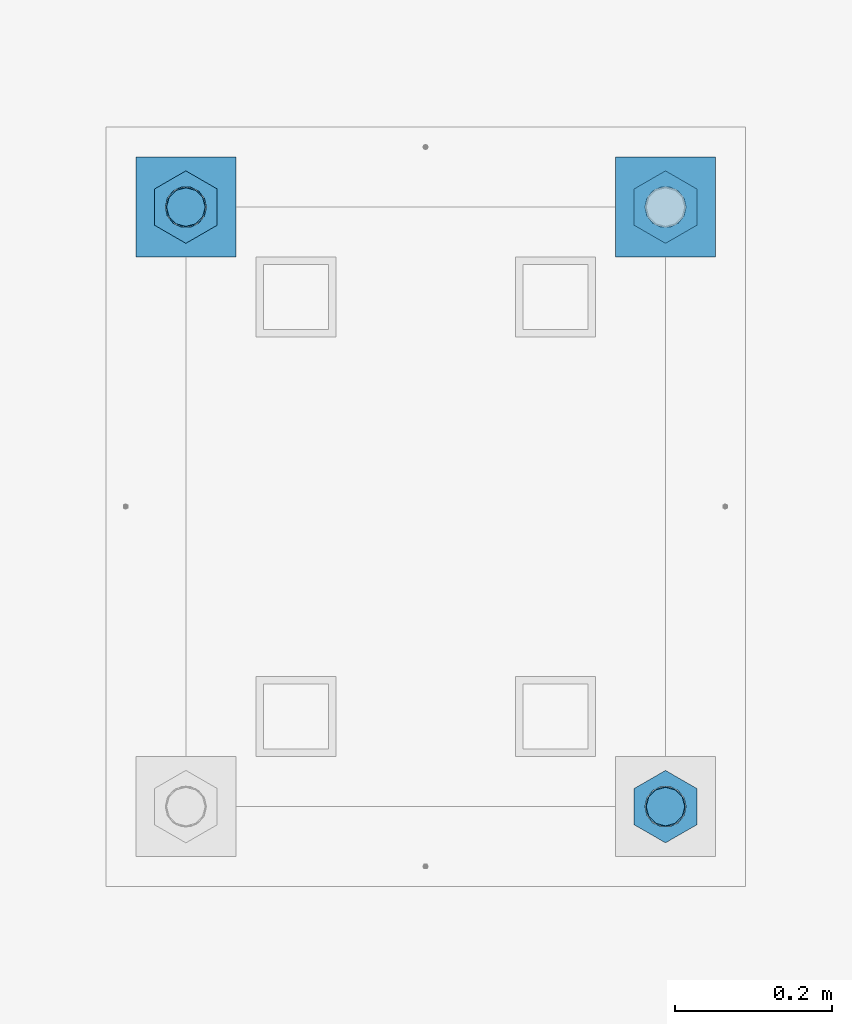
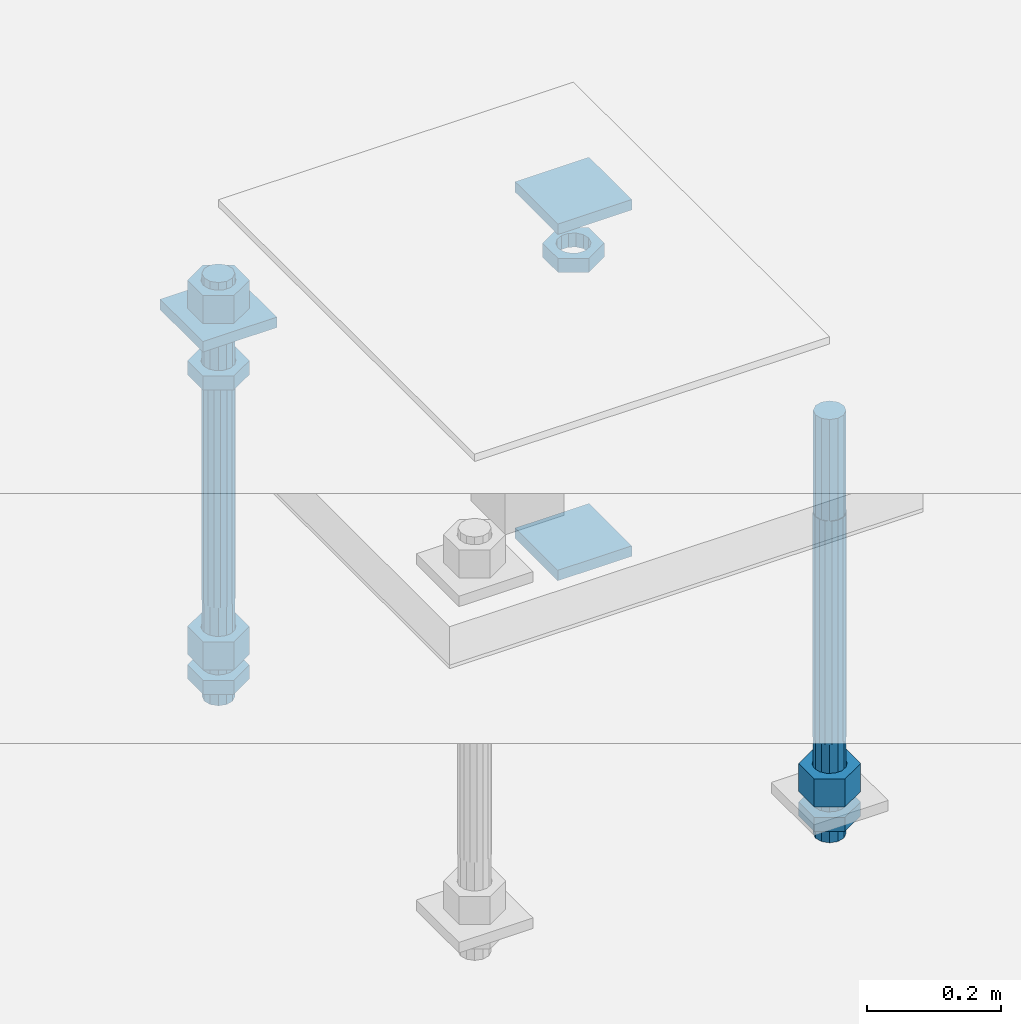
# One storey, part 2623 of 3843: 12 beams, 1 element without a shape of its own.
"""IFC2X3 building model written with IfcOpenShell, lengths in millimetres."""

from ifc_helpers import new_model, si_unit, frame, origin_with_axes, place, context, subcontext, project, spatial, faceted_brep, material, type_object, element, aggregate, save


model = new_model("IFC2X3")

# Units and contexts
model_context = context("Model", 3, precision=1e-05, world=origin_with_axes())
body_context = subcontext(model_context, "Body", "Model", "MODEL_VIEW")
ifc_project = project(units=[si_unit("LENGTHUNIT", "METRE", prefix="MILLI"), si_unit("AREAUNIT", "SQUARE_METRE"), si_unit("VOLUMEUNIT", "CUBIC_METRE"), si_unit("MASSUNIT", "GRAM", prefix="KILO"), si_unit("TIMEUNIT", "SECOND"), si_unit("PLANEANGLEUNIT", "RADIAN"), si_unit("SOLIDANGLEUNIT", "STERADIAN"), si_unit("THERMODYNAMICTEMPERATUREUNIT", "DEGREE_CELSIUS"), si_unit("LUMINOUSINTENSITYUNIT", "LUMEN")], contexts=[model_context])

# Site, building, storey
site_placement = place(None, origin_with_axes())
site = spatial("IfcSite", under=ifc_project, at=site_placement, CompositionType="ELEMENT")
building_placement = place(site_placement, origin_with_axes())
building = spatial("IfcBuilding", under=site, at=building_placement, Name="Undefined", CompositionType="ELEMENT")
storey_placement = place(building_placement, origin_with_axes())
storey = spatial("IfcBuildingStorey", under=building, at=storey_placement, Name="Undefined", CompositionType="ELEMENT", Elevation=0.0)

# Assembly, beams
assembly_placement = place(storey_placement, origin_with_axes())
assembly = element("IfcElementAssembly", 1, at=assembly_placement, inside=storey, Name="TEMPLATE", AssemblyPlace="NOTDEFINED", PredefinedType="RIGID_FRAME")
ifc_material_1 = material(Name="STEEL/A36")
beam_type_1 = type_object("IfcBeamType", PredefinedType="NOTDEFINED")
beam_1_placement = place(assembly_placement, frame((116471.7, 2032.0, 29873.575), z_axis=(0.0, 1.0, 0.0), x_axis=(-1.0, 0.0, 0.0)))
beam_1 = element("IfcBeam", 2, at=beam_1_placement, type_object=beam_type_1, material=ifc_material_1, Name="WASHER_PLATE", context=body_context, shape_type="Brep", body=[
    faceted_brep([(0.0, 9.52500000000146, -63.5), (0.0, 9.52500000000146, 63.5), (127.0, 9.52500000000146, 63.5), (127.0, 9.52500000000146, -63.5), (0.0, -9.52500000000146, 63.5), (127.0, -9.52500000000146, 63.5), (0.0, -9.52500000000146, -63.5), (127.0, -9.52500000000146, -63.5)], [[[0, 1, 2, 3]], [[1, 4, 5, 2]], [[4, 6, 7, 5]], [[6, 0, 3, 7]], [[5, 7, 3, 2]], [[6, 4, 1, 0]]]),
])
beam_2_placement = place(assembly_placement, frame((115862.099998474, 2032.0, 29873.575), z_axis=(0.0, 1.0, 0.0), x_axis=(-1.0, 0.0, 0.0)))
beam_2 = element("IfcBeam", 3, at=beam_2_placement, type_object=beam_type_1, material=ifc_material_1, Name="WASHER_PLATE", context=body_context, shape_type="Brep", body=[
    faceted_brep([(0.0, 9.52500000000146, -63.5), (0.0, 9.52500000000146, 63.5), (127.0, 9.52500000000146, 63.5), (127.0, 9.52500000000146, -63.5), (0.0, -9.52500000000146, 63.5), (127.0, -9.52500000000146, 63.5), (0.0, -9.52500000000146, -63.5), (127.0, -9.52500000000146, -63.5)], [[[0, 1, 2, 3]], [[1, 4, 5, 2]], [[4, 6, 7, 5]], [[6, 0, 3, 7]], [[5, 7, 3, 2]], [[6, 4, 1, 0]]]),
])
beam_3_placement = place(assembly_placement, frame((116471.7, 2032.00000000001, 29244.925), z_axis=(0.0, 1.0, 0.0), x_axis=(-1.0, 0.0, 0.0)))
beam_3 = element("IfcBeam", 4, at=beam_3_placement, type_object=beam_type_1, material=ifc_material_1, Name="WASHER_PLATE", context=body_context, shape_type="Brep", body=[
    faceted_brep([(0.0, 9.52500000000146, -63.5), (0.0, 9.52500000000146, 63.5), (127.0, 9.52500000000146, 63.5), (127.0, 9.52500000000146, -63.5), (0.0, -9.52500000000146, 63.5), (127.0, -9.52500000000146, 63.5), (0.0, -9.52500000000146, -63.5), (127.0, -9.52500000000146, -63.5)], [[[0, 1, 2, 3]], [[1, 4, 5, 2]], [[4, 6, 7, 5]], [[6, 0, 3, 7]], [[5, 7, 3, 2]], [[6, 4, 1, 0]]]),
])
beam_type_2 = type_object("IfcBeamType", Name="2_HALF_NUT", PredefinedType="NOTDEFINED")
beam_4_placement = place(assembly_placement, frame((115798.599998474, 2032.00000000001, 29787.85), z_axis=(-1.0, 0.0, 0.0), x_axis=(0.0, 0.0, -1.0)))
beam_4 = element("IfcBeam", 5, at=beam_4_placement, type_object=beam_type_2, material=ifc_material_1, Name="NUT", ObjectType="2_HALF_NUT", context=body_context, shape_type="Brep", body=[
    faceted_brep([(0.0, -46.0369987487793, 0.0), (0.0, -23.0184993743896, -39.869213104248), (25.4000000000015, -23.0184993743896, -39.869213104248), (25.4000000000015, -46.0369987487793, 0.0), (0.0, 23.0184993743896, -39.869213104248), (25.4000000000015, 23.0184993743896, -39.869213104248), (0.0, 46.0369987487793, 0.0), (25.4000000000015, 46.0369987487793, 0.0), (0.0, 23.0184993743896, 39.869213104248), (25.4000000000015, 23.0184993743896, 39.869213104248), (0.0, -23.0184993743896, 39.869213104248), (25.4000000000015, -23.0184993743896, 39.869213104248), (0.0, 0.0, 26.1940002441406), (0.0, 11.3650617044477, 23.5999013092805), (25.4000000000015, 11.3650617044477, 23.5999013092805), (25.4000000000015, 0.0, 26.1940002441406), (0.0, 20.4791109456419, 16.3316083006721), (25.4000000000015, 20.4791109456419, 16.3316083006721), (0.0, 25.5370200498292, 5.82867859874386), (25.4000000000015, 25.5370200498292, 5.82867859874386), (0.0, 25.5370200498292, -5.82867859874386), (25.4000000000015, 25.5370200498292, -5.82867859874386), (0.0, 20.4791109456419, -16.3316083006721), (25.4000000000015, 20.4791109456419, -16.3316083006721), (0.0, 11.3650617044477, -23.5999013092805), (25.4000000000015, 11.3650617044477, -23.5999013092805), (0.0, 0.0, -26.1940002441406), (25.4000000000015, 0.0, -26.1940002441406), (0.0, -11.3650617044477, -23.5999013092805), (25.4000000000015, -11.3650617044477, -23.5999013092805), (0.0, -20.4791109456419, -16.3316083006721), (25.4000000000015, -20.4791109456419, -16.3316083006721), (0.0, -25.5370200498292, -5.82867859874386), (25.4000000000015, -25.5370200498292, -5.82867859874386), (0.0, -25.5370200498292, 5.82867859874386), (25.4000000000015, -25.5370200498292, 5.82867859874386), (0.0, -20.4791109456419, 16.3316083006721), (25.4000000000015, -20.4791109456419, 16.3316083006721), (0.0, -11.3650617044477, 23.5999013092805), (25.4000000000015, -11.3650617044477, 23.5999013092805)], [[[0, 1, 2, 3]], [[1, 4, 5, 2]], [[4, 6, 7, 5]], [[6, 8, 9, 7]], [[8, 10, 11, 9]], [[10, 0, 3, 11]], [[12, 13, 14, 15]], [[13, 16, 17, 14]], [[16, 18, 19, 17]], [[18, 20, 21, 19]], [[20, 22, 23, 21]], [[22, 24, 25, 23]], [[24, 26, 27, 25]], [[26, 28, 29, 27]], [[28, 30, 31, 29]], [[30, 32, 33, 31]], [[32, 34, 35, 33]], [[34, 36, 37, 35]], [[36, 38, 39, 37]], [[38, 12, 15, 39]], [[5, 7, 9, 11, 3, 2], [17, 19, 21, 23, 25, 27, 29, 31, 33, 35, 37, 39, 15, 14]], [[10, 8, 6, 4, 1, 0], [38, 36, 34, 32, 30, 28, 26, 24, 22, 20, 18, 16, 13, 12]]]),
])
beam_5_placement = place(assembly_placement, frame((115798.599998474, 2032.0, 29235.4), z_axis=(-1.0, 0.0, 0.0), x_axis=(0.0, 0.0, -1.0)))
beam_5 = element("IfcBeam", 6, at=beam_5_placement, type_object=beam_type_2, material=ifc_material_1, Name="NUT", ObjectType="2_HALF_NUT", context=body_context, shape_type="Brep", body=[
    faceted_brep([(0.0, -46.0369987487793, 0.0), (0.0, -23.0184993743896, -39.869213104248), (25.4000000000015, -23.0184993743896, -39.869213104248), (25.4000000000015, -46.0369987487793, 0.0), (0.0, 23.0184993743896, -39.869213104248), (25.4000000000015, 23.0184993743896, -39.869213104248), (0.0, 46.0369987487793, 0.0), (25.4000000000015, 46.0369987487793, 0.0), (0.0, 23.0184993743896, 39.869213104248), (25.4000000000015, 23.0184993743896, 39.869213104248), (0.0, -23.0184993743896, 39.869213104248), (25.4000000000015, -23.0184993743896, 39.869213104248), (0.0, 0.0, 26.1940002441406), (0.0, 11.3650617044477, 23.5999013092805), (25.4000000000015, 11.3650617044477, 23.5999013092805), (25.4000000000015, 0.0, 26.1940002441406), (0.0, 20.4791109456419, 16.3316083006721), (25.4000000000015, 20.4791109456419, 16.3316083006721), (0.0, 25.5370200498292, 5.82867859874386), (25.4000000000015, 25.5370200498292, 5.82867859874386), (0.0, 25.5370200498292, -5.82867859874386), (25.4000000000015, 25.5370200498292, -5.82867859874386), (0.0, 20.4791109456419, -16.3316083006721), (25.4000000000015, 20.4791109456419, -16.3316083006721), (0.0, 11.3650617044477, -23.5999013092805), (25.4000000000015, 11.3650617044477, -23.5999013092805), (0.0, 0.0, -26.1940002441406), (25.4000000000015, 0.0, -26.1940002441406), (0.0, -11.3650617044477, -23.5999013092805), (25.4000000000015, -11.3650617044477, -23.5999013092805), (0.0, -20.4791109456419, -16.3316083006721), (25.4000000000015, -20.4791109456419, -16.3316083006721), (0.0, -25.5370200498292, -5.82867859874386), (25.4000000000015, -25.5370200498292, -5.82867859874386), (0.0, -25.5370200498292, 5.82867859874386), (25.4000000000015, -25.5370200498292, 5.82867859874386), (0.0, -20.4791109456419, 16.3316083006721), (25.4000000000015, -20.4791109456419, 16.3316083006721), (0.0, -11.3650617044477, 23.5999013092805), (25.4000000000015, -11.3650617044477, 23.5999013092805)], [[[0, 1, 2, 3]], [[1, 4, 5, 2]], [[4, 6, 7, 5]], [[6, 8, 9, 7]], [[8, 10, 11, 9]], [[10, 0, 3, 11]], [[12, 13, 14, 15]], [[13, 16, 17, 14]], [[16, 18, 19, 17]], [[18, 20, 21, 19]], [[20, 22, 23, 21]], [[22, 24, 25, 23]], [[24, 26, 27, 25]], [[26, 28, 29, 27]], [[28, 30, 31, 29]], [[30, 32, 33, 31]], [[32, 34, 35, 33]], [[34, 36, 37, 35]], [[36, 38, 39, 37]], [[38, 12, 15, 39]], [[5, 7, 9, 11, 3, 2], [17, 19, 21, 23, 25, 27, 29, 31, 33, 35, 37, 39, 15, 14]], [[10, 8, 6, 4, 1, 0], [38, 36, 34, 32, 30, 28, 26, 24, 22, 20, 18, 16, 13, 12]]]),
])
beam_6_placement = place(assembly_placement, frame((116408.2, 1270.0, 29235.4), z_axis=(-1.0, 0.0, 0.0), x_axis=(0.0, 0.0, -1.0)))
beam_6 = element("IfcBeam", 7, at=beam_6_placement, type_object=beam_type_2, material=ifc_material_1, Name="NUT", ObjectType="2_HALF_NUT", context=body_context, shape_type="Brep", body=[
    faceted_brep([(0.0, -46.0369987487793, 0.0), (0.0, -23.0184993743896, -39.869213104248), (25.4000000000015, -23.0184993743896, -39.869213104248), (25.4000000000015, -46.0369987487793, 0.0), (0.0, 23.0184993743896, -39.869213104248), (25.4000000000015, 23.0184993743896, -39.869213104248), (0.0, 46.0369987487793, 0.0), (25.4000000000015, 46.0369987487793, 0.0), (0.0, 23.0184993743896, 39.869213104248), (25.4000000000015, 23.0184993743896, 39.869213104248), (0.0, -23.0184993743896, 39.869213104248), (25.4000000000015, -23.0184993743896, 39.869213104248), (0.0, 0.0, 26.1940002441406), (0.0, 11.3650617044477, 23.5999013092805), (25.4000000000015, 11.3650617044477, 23.5999013092805), (25.4000000000015, 0.0, 26.1940002441406), (0.0, 20.4791109456419, 16.3316083006721), (25.4000000000015, 20.4791109456419, 16.3316083006721), (0.0, 25.5370200498292, 5.82867859874386), (25.4000000000015, 25.5370200498292, 5.82867859874386), (0.0, 25.5370200498292, -5.82867859874386), (25.4000000000015, 25.5370200498292, -5.82867859874386), (0.0, 20.4791109456419, -16.3316083006721), (25.4000000000015, 20.4791109456419, -16.3316083006721), (0.0, 11.3650617044477, -23.5999013092805), (25.4000000000015, 11.3650617044477, -23.5999013092805), (0.0, 0.0, -26.1940002441406), (25.4000000000015, 0.0, -26.1940002441406), (0.0, -11.3650617044477, -23.5999013092805), (25.4000000000015, -11.3650617044477, -23.5999013092805), (0.0, -20.4791109456419, -16.3316083006721), (25.4000000000015, -20.4791109456419, -16.3316083006721), (0.0, -25.5370200498292, -5.82867859874386), (25.4000000000015, -25.5370200498292, -5.82867859874386), (0.0, -25.5370200498292, 5.82867859874386), (25.4000000000015, -25.5370200498292, 5.82867859874386), (0.0, -20.4791109456419, 16.3316083006721), (25.4000000000015, -20.4791109456419, 16.3316083006721), (0.0, -11.3650617044477, 23.5999013092805), (25.4000000000015, -11.3650617044477, 23.5999013092805)], [[[0, 1, 2, 3]], [[1, 4, 5, 2]], [[4, 6, 7, 5]], [[6, 8, 9, 7]], [[8, 10, 11, 9]], [[10, 0, 3, 11]], [[12, 13, 14, 15]], [[13, 16, 17, 14]], [[16, 18, 19, 17]], [[18, 20, 21, 19]], [[20, 22, 23, 21]], [[22, 24, 25, 23]], [[24, 26, 27, 25]], [[26, 28, 29, 27]], [[28, 30, 31, 29]], [[30, 32, 33, 31]], [[32, 34, 35, 33]], [[34, 36, 37, 35]], [[36, 38, 39, 37]], [[38, 12, 15, 39]], [[5, 7, 9, 11, 3, 2], [17, 19, 21, 23, 25, 27, 29, 31, 33, 35, 37, 39, 15, 14]], [[10, 8, 6, 4, 1, 0], [38, 36, 34, 32, 30, 28, 26, 24, 22, 20, 18, 16, 13, 12]]]),
])
beam_7_placement = place(assembly_placement, frame((116408.2, 2032.00000000001, 29787.85), z_axis=(-1.0, 0.0, 0.0), x_axis=(0.0, 0.0, -1.0)))
beam_7 = element("IfcBeam", 8, at=beam_7_placement, type_object=beam_type_2, material=ifc_material_1, Name="NUT", ObjectType="2_HALF_NUT", context=body_context, shape_type="Brep", body=[
    faceted_brep([(0.0, -46.0369987487793, 0.0), (0.0, -23.0184993743896, -39.869213104248), (25.4000000000015, -23.0184993743896, -39.869213104248), (25.4000000000015, -46.0369987487793, 0.0), (0.0, 23.0184993743896, -39.869213104248), (25.4000000000015, 23.0184993743896, -39.869213104248), (0.0, 46.0369987487793, 0.0), (25.4000000000015, 46.0369987487793, 0.0), (0.0, 23.0184993743896, 39.869213104248), (25.4000000000015, 23.0184993743896, 39.869213104248), (0.0, -23.0184993743896, 39.869213104248), (25.4000000000015, -23.0184993743896, 39.869213104248), (0.0, 0.0, 26.1940002441406), (0.0, 11.3650617044477, 23.5999013092805), (25.4000000000015, 11.3650617044477, 23.5999013092805), (25.4000000000015, 0.0, 26.1940002441406), (0.0, 20.4791109456419, 16.3316083006721), (25.4000000000015, 20.4791109456419, 16.3316083006721), (0.0, 25.5370200498292, 5.82867859874386), (25.4000000000015, 25.5370200498292, 5.82867859874386), (0.0, 25.5370200498292, -5.82867859874386), (25.4000000000015, 25.5370200498292, -5.82867859874386), (0.0, 20.4791109456419, -16.3316083006721), (25.4000000000015, 20.4791109456419, -16.3316083006721), (0.0, 11.3650617044477, -23.5999013092805), (25.4000000000015, 11.3650617044477, -23.5999013092805), (0.0, 0.0, -26.1940002441406), (25.4000000000015, 0.0, -26.1940002441406), (0.0, -11.3650617044477, -23.5999013092805), (25.4000000000015, -11.3650617044477, -23.5999013092805), (0.0, -20.4791109456419, -16.3316083006721), (25.4000000000015, -20.4791109456419, -16.3316083006721), (0.0, -25.5370200498292, -5.82867859874386), (25.4000000000015, -25.5370200498292, -5.82867859874386), (0.0, -25.5370200498292, 5.82867859874386), (25.4000000000015, -25.5370200498292, 5.82867859874386), (0.0, -20.4791109456419, 16.3316083006721), (25.4000000000015, -20.4791109456419, 16.3316083006721), (0.0, -11.3650617044477, 23.5999013092805), (25.4000000000015, -11.3650617044477, 23.5999013092805)], [[[0, 1, 2, 3]], [[1, 4, 5, 2]], [[4, 6, 7, 5]], [[6, 8, 9, 7]], [[8, 10, 11, 9]], [[10, 0, 3, 11]], [[12, 13, 14, 15]], [[13, 16, 17, 14]], [[16, 18, 19, 17]], [[18, 20, 21, 19]], [[20, 22, 23, 21]], [[22, 24, 25, 23]], [[24, 26, 27, 25]], [[26, 28, 29, 27]], [[28, 30, 31, 29]], [[30, 32, 33, 31]], [[32, 34, 35, 33]], [[34, 36, 37, 35]], [[36, 38, 39, 37]], [[38, 12, 15, 39]], [[5, 7, 9, 11, 3, 2], [17, 19, 21, 23, 25, 27, 29, 31, 33, 35, 37, 39, 15, 14]], [[10, 8, 6, 4, 1, 0], [38, 36, 34, 32, 30, 28, 26, 24, 22, 20, 18, 16, 13, 12]]]),
])
beam_type_3 = type_object("IfcBeamType", Name="2_HEAVY_HEX_NUT", PredefinedType="NOTDEFINED")
beam_8_placement = place(assembly_placement, frame((115798.599998474, 2032.00000000001, 29933.9), z_axis=(-1.0, 0.0, 0.0), x_axis=(0.0, 0.0, -1.0)))
beam_8 = element("IfcBeam", 9, at=beam_8_placement, type_object=beam_type_3, material=ifc_material_1, Name="NUT", ObjectType="2_HEAVY_HEX_NUT", context=body_context, shape_type="Brep", body=[
    faceted_brep([(0.0, -46.0369987487793, 0.0), (0.0, -23.0184993743896, -39.869213104248), (50.7999999999993, -23.0184993743896, -39.869213104248), (50.7999999999993, -46.0369987487793, 0.0), (0.0, 23.0184993743896, -39.869213104248), (50.7999999999993, 23.0184993743896, -39.869213104248), (0.0, 46.0369987487793, 0.0), (50.7999999999993, 46.0369987487793, 0.0), (0.0, 23.0184993743896, 39.869213104248), (50.7999999999993, 23.0184993743896, 39.869213104248), (0.0, -23.0184993743896, 39.869213104248), (50.7999999999993, -23.0184993743896, 39.869213104248), (0.0, 0.0, 26.1940002441406), (0.0, 11.3650617044477, 23.5999013092805), (50.7999999999993, 11.3650617044477, 23.5999013092805), (50.7999999999993, 0.0, 26.1940002441406), (0.0, 20.4791109456419, 16.3316083006721), (50.7999999999993, 20.4791109456419, 16.3316083006721), (0.0, 25.5370200498292, 5.82867859874386), (50.7999999999993, 25.5370200498292, 5.82867859874386), (0.0, 25.5370200498292, -5.82867859874386), (50.7999999999993, 25.5370200498292, -5.82867859874386), (0.0, 20.4791109456419, -16.3316083006721), (50.7999999999993, 20.4791109456419, -16.3316083006721), (0.0, 11.3650617044477, -23.5999013092805), (50.7999999999993, 11.3650617044477, -23.5999013092805), (0.0, 0.0, -26.1940002441406), (50.7999999999993, 0.0, -26.1940002441406), (0.0, -11.3650617044477, -23.5999013092805), (50.7999999999993, -11.3650617044477, -23.5999013092805), (0.0, -20.4791109456419, -16.3316083006721), (50.7999999999993, -20.4791109456419, -16.3316083006721), (0.0, -25.5370200498292, -5.82867859874386), (50.7999999999993, -25.5370200498292, -5.82867859874386), (0.0, -25.5370200498292, 5.82867859874386), (50.7999999999993, -25.5370200498292, 5.82867859874386), (0.0, -20.4791109456419, 16.3316083006721), (50.7999999999993, -20.4791109456419, 16.3316083006721), (0.0, -11.3650617044477, 23.5999013092805), (50.7999999999993, -11.3650617044477, 23.5999013092805)], [[[0, 1, 2, 3]], [[1, 4, 5, 2]], [[4, 6, 7, 5]], [[6, 8, 9, 7]], [[8, 10, 11, 9]], [[10, 0, 3, 11]], [[12, 13, 14, 15]], [[13, 16, 17, 14]], [[16, 18, 19, 17]], [[18, 20, 21, 19]], [[20, 22, 23, 21]], [[22, 24, 25, 23]], [[24, 26, 27, 25]], [[26, 28, 29, 27]], [[28, 30, 31, 29]], [[30, 32, 33, 31]], [[32, 34, 35, 33]], [[34, 36, 37, 35]], [[36, 38, 39, 37]], [[38, 12, 15, 39]], [[5, 7, 9, 11, 3, 2], [17, 19, 21, 23, 25, 27, 29, 31, 33, 35, 37, 39, 15, 14]], [[10, 8, 6, 4, 1, 0], [38, 36, 34, 32, 30, 28, 26, 24, 22, 20, 18, 16, 13, 12]]]),
])
beam_9_placement = place(assembly_placement, frame((115798.599998474, 2032.00000000001, 29305.25), z_axis=(-1.0, 0.0, 0.0), x_axis=(0.0, 0.0, -1.0)))
beam_9 = element("IfcBeam", 10, at=beam_9_placement, type_object=beam_type_3, material=ifc_material_1, Name="NUT", ObjectType="2_HEAVY_HEX_NUT", context=body_context, shape_type="Brep", body=[
    faceted_brep([(0.0, -46.0369987487793, 0.0), (0.0, -23.0184993743896, -39.869213104248), (50.7999999999993, -23.0184993743896, -39.869213104248), (50.7999999999993, -46.0369987487793, 0.0), (0.0, 23.0184993743896, -39.869213104248), (50.7999999999993, 23.0184993743896, -39.869213104248), (0.0, 46.0369987487793, 0.0), (50.7999999999993, 46.0369987487793, 0.0), (0.0, 23.0184993743896, 39.869213104248), (50.7999999999993, 23.0184993743896, 39.869213104248), (0.0, -23.0184993743896, 39.869213104248), (50.7999999999993, -23.0184993743896, 39.869213104248), (0.0, 0.0, 26.1940002441406), (0.0, 11.3650617044477, 23.5999013092805), (50.7999999999993, 11.3650617044477, 23.5999013092805), (50.7999999999993, 0.0, 26.1940002441406), (0.0, 20.4791109456419, 16.3316083006721), (50.7999999999993, 20.4791109456419, 16.3316083006721), (0.0, 25.5370200498292, 5.82867859874386), (50.7999999999993, 25.5370200498292, 5.82867859874386), (0.0, 25.5370200498292, -5.82867859874386), (50.7999999999993, 25.5370200498292, -5.82867859874386), (0.0, 20.4791109456419, -16.3316083006721), (50.7999999999993, 20.4791109456419, -16.3316083006721), (0.0, 11.3650617044477, -23.5999013092805), (50.7999999999993, 11.3650617044477, -23.5999013092805), (0.0, 0.0, -26.1940002441406), (50.7999999999993, 0.0, -26.1940002441406), (0.0, -11.3650617044477, -23.5999013092805), (50.7999999999993, -11.3650617044477, -23.5999013092805), (0.0, -20.4791109456419, -16.3316083006721), (50.7999999999993, -20.4791109456419, -16.3316083006721), (0.0, -25.5370200498292, -5.82867859874386), (50.7999999999993, -25.5370200498292, -5.82867859874386), (0.0, -25.5370200498292, 5.82867859874386), (50.7999999999993, -25.5370200498292, 5.82867859874386), (0.0, -20.4791109456419, 16.3316083006721), (50.7999999999993, -20.4791109456419, 16.3316083006721), (0.0, -11.3650617044477, 23.5999013092805), (50.7999999999993, -11.3650617044477, 23.5999013092805)], [[[0, 1, 2, 3]], [[1, 4, 5, 2]], [[4, 6, 7, 5]], [[6, 8, 9, 7]], [[8, 10, 11, 9]], [[10, 0, 3, 11]], [[12, 13, 14, 15]], [[13, 16, 17, 14]], [[16, 18, 19, 17]], [[18, 20, 21, 19]], [[20, 22, 23, 21]], [[22, 24, 25, 23]], [[24, 26, 27, 25]], [[26, 28, 29, 27]], [[28, 30, 31, 29]], [[30, 32, 33, 31]], [[32, 34, 35, 33]], [[34, 36, 37, 35]], [[36, 38, 39, 37]], [[38, 12, 15, 39]], [[5, 7, 9, 11, 3, 2], [17, 19, 21, 23, 25, 27, 29, 31, 33, 35, 37, 39, 15, 14]], [[10, 8, 6, 4, 1, 0], [38, 36, 34, 32, 30, 28, 26, 24, 22, 20, 18, 16, 13, 12]]]),
])
beam_10_placement = place(assembly_placement, frame((116408.2, 1270.00000000001, 29305.25), z_axis=(-1.0, 0.0, 0.0), x_axis=(0.0, 0.0, -1.0)))
beam_10 = element("IfcBeam", 11, at=beam_10_placement, type_object=beam_type_3, material=ifc_material_1, Name="NUT", ObjectType="2_HEAVY_HEX_NUT", context=body_context, shape_type="Brep", body=[
    faceted_brep([(0.0, -46.0369987487793, 0.0), (0.0, -23.0184993743896, -39.869213104248), (50.7999999999993, -23.0184993743896, -39.869213104248), (50.7999999999993, -46.0369987487793, 0.0), (0.0, 23.0184993743896, -39.869213104248), (50.7999999999993, 23.0184993743896, -39.869213104248), (0.0, 46.0369987487793, 0.0), (50.7999999999993, 46.0369987487793, 0.0), (0.0, 23.0184993743896, 39.869213104248), (50.7999999999993, 23.0184993743896, 39.869213104248), (0.0, -23.0184993743896, 39.869213104248), (50.7999999999993, -23.0184993743896, 39.869213104248), (0.0, 0.0, 26.1940002441406), (0.0, 11.3650617044477, 23.5999013092805), (50.7999999999993, 11.3650617044477, 23.5999013092805), (50.7999999999993, 0.0, 26.1940002441406), (0.0, 20.4791109456419, 16.3316083006721), (50.7999999999993, 20.4791109456419, 16.3316083006721), (0.0, 25.5370200498292, 5.82867859874386), (50.7999999999993, 25.5370200498292, 5.82867859874386), (0.0, 25.5370200498292, -5.82867859874386), (50.7999999999993, 25.5370200498292, -5.82867859874386), (0.0, 20.4791109456419, -16.3316083006721), (50.7999999999993, 20.4791109456419, -16.3316083006721), (0.0, 11.3650617044477, -23.5999013092805), (50.7999999999993, 11.3650617044477, -23.5999013092805), (0.0, 0.0, -26.1940002441406), (50.7999999999993, 0.0, -26.1940002441406), (0.0, -11.3650617044477, -23.5999013092805), (50.7999999999993, -11.3650617044477, -23.5999013092805), (0.0, -20.4791109456419, -16.3316083006721), (50.7999999999993, -20.4791109456419, -16.3316083006721), (0.0, -25.5370200498292, -5.82867859874386), (50.7999999999993, -25.5370200498292, -5.82867859874386), (0.0, -25.5370200498292, 5.82867859874386), (50.7999999999993, -25.5370200498292, 5.82867859874386), (0.0, -20.4791109456419, 16.3316083006721), (50.7999999999993, -20.4791109456419, 16.3316083006721), (0.0, -11.3650617044477, 23.5999013092805), (50.7999999999993, -11.3650617044477, 23.5999013092805)], [[[0, 1, 2, 3]], [[1, 4, 5, 2]], [[4, 6, 7, 5]], [[6, 8, 9, 7]], [[8, 10, 11, 9]], [[10, 0, 3, 11]], [[12, 13, 14, 15]], [[13, 16, 17, 14]], [[16, 18, 19, 17]], [[18, 20, 21, 19]], [[20, 22, 23, 21]], [[22, 24, 25, 23]], [[24, 26, 27, 25]], [[26, 28, 29, 27]], [[28, 30, 31, 29]], [[30, 32, 33, 31]], [[32, 34, 35, 33]], [[34, 36, 37, 35]], [[36, 38, 39, 37]], [[38, 12, 15, 39]], [[5, 7, 9, 11, 3, 2], [17, 19, 21, 23, 25, 27, 29, 31, 33, 35, 37, 39, 15, 14]], [[10, 8, 6, 4, 1, 0], [38, 36, 34, 32, 30, 28, 26, 24, 22, 20, 18, 16, 13, 12]]]),
])
ifc_material_2 = material()
beam_type_4 = type_object("IfcBeamType", PredefinedType="NOTDEFINED")
beam_11_placement = place(assembly_placement, frame((115798.599998474, 2032.00000000001, 29762.45), z_axis=(-1.0, 0.0, 0.0), x_axis=(0.0, 0.0, -1.0)))
beam_11 = element("IfcBeam", 12, at=beam_11_placement, type_object=beam_type_4, material=ifc_material_2, Name="ANCHOR_ROD", context=body_context, shape_type="Brep", body=[
    faceted_brep([(-184.150000000001, -21.217622392709, 12.25), (-184.150000000001, -12.2499999999854, 21.2176223927163), (-184.150000000001, 1.45519152283669e-11, 24.5), (-184.150000000001, 12.2500000000146, 21.2176223927163), (-184.150000000001, 21.2176223927381, 12.25), (-184.150000000001, 24.5000000000146, 0.0), (-184.150000000001, 21.2176223927381, -12.25), (-184.150000000001, 12.2500000000146, -21.2176223927163), (-184.150000000001, 1.45519152283669e-11, -24.5), (-184.150000000001, -12.2499999999854, -21.2176223927163), (-184.150000000001, -21.217622392709, -12.25), (-184.150000000001, -24.4999999999854, 0.0), (0.0, 24.5000000000146, 0.0), (0.0, 21.2176223927381, -12.25), (0.0, 12.2500000000146, -21.2176223927163), (0.0, 1.45519152283669e-11, -24.5), (0.0, -12.2499999999854, -21.2176223927163), (0.0, -21.217622392709, -12.25), (0.0, -24.4999999999854, 0.0), (0.0, -21.217622392709, 12.25), (0.0, -12.2499999999854, 21.2176223927163), (0.0, 1.45519152283669e-11, 24.5), (0.0, 12.2500000000146, 21.2176223927163), (0.0, 21.2176223927381, 12.25), (0.0, -23.4665401257807, 9.72015918207035), (0.0, -17.9605122421344, 17.9605122421417), (0.0, -9.72015918207762, 23.466540125788), (0.0, 0.0, 25.4000000000015), (0.0, 9.72015918207762, 23.466540125788), (0.0, 17.9605122421344, 17.9605122421417), (0.0, 23.4665401257807, 9.72015918207035), (0.0, 25.3999996185303, 0.0), (0.0, 23.4665401257807, -9.72015918207035), (0.0, 17.9605122421344, -17.9605122421417), (0.0, 9.72015918207762, -23.466540125788), (0.0, 0.0, -25.4000000000015), (0.0, -9.72015918207762, -23.466540125788), (0.0, -17.9605122421344, -17.9605122421417), (0.0, -23.4665401257807, -9.72015918207035), (0.0, -25.3999996185303, 0.0), (406.399999999998, -25.3999999999942, 0.0), (406.399999999998, -23.4665401257807, 9.72015918207035), (406.399999999998, -17.9605122421344, 17.9605122421417), (406.399999999998, -9.72015918207762, 23.466540125788), (406.399999999998, 0.0, 25.4000000000015), (406.399999999998, 9.72015918207762, 23.466540125788), (406.399999999998, 17.9605122421344, 17.9605122421417), (406.399999999998, 23.4665401257807, 9.72015918207035), (406.399999999998, 25.3999999999942, 0.0), (406.399999999998, 23.4665401257807, -9.72015918207035), (406.399999999998, 17.9605122421344, -17.9605122421417), (406.399999999998, 9.72015918207762, -23.466540125788), (406.399999999998, 0.0, -25.4000000000015), (406.399999999998, -9.72015918207762, -23.466540125788), (406.399999999998, -17.9605122421344, -17.9605122421417), (406.399999999998, -23.4665401257807, -9.72015918207035), (406.399999999998, -12.2499999999854, 21.2176223927163), (406.399999999998, 1.45519152283669e-11, 24.5), (406.399999999998, 12.2500000000146, 21.2176223927163), (406.399999999998, 21.2176223927381, 12.25), (406.399999999998, 24.5000000000146, 0.0), (406.399999999998, 21.2176223927381, -12.25), (406.399999999998, 12.2500000000146, -21.2176223927163), (406.399999999998, 1.45519152283669e-11, -24.5), (406.399999999998, -12.2499999999854, -21.2176223927163), (406.399999999998, -21.217622392709, -12.25), (406.399999999998, -24.4999999999854, 0.0), (406.399999999998, -21.217622392709, 12.25), (584.200000000001, -12.2499999999854, -21.2176223927163), (584.200000000001, 1.45519152283669e-11, -24.5), (584.200000000001, 12.2500000000146, -21.2176223927163), (584.200000000001, 21.2176223927381, -12.25), (584.200000000001, 24.5000000000146, 0.0), (584.200000000001, 21.2176223927381, 12.25), (584.200000000001, 12.2500000000146, 21.2176223927163), (584.200000000001, 1.45519152283669e-11, 24.5), (584.200000000001, -12.2499999999854, 21.2176223927163), (584.200000000001, -21.217622392709, 12.25), (584.200000000001, -24.4999999999854, 0.0), (584.200000000001, -21.217622392709, -12.25)], [[[0, 1, 2, 3, 4, 5, 6, 7, 8, 9, 10, 11]], [[6, 5, 12, 13]], [[7, 6, 13, 14]], [[8, 7, 14, 15]], [[9, 8, 15, 16]], [[10, 9, 16, 17]], [[11, 10, 17, 18]], [[0, 11, 18, 19]], [[1, 0, 19, 20]], [[2, 1, 20, 21]], [[3, 2, 21, 22]], [[4, 3, 22, 23]], [[5, 4, 23, 12]], [[24, 25, 26, 27, 28, 29, 30, 31, 32, 33, 34, 35, 36, 37, 38, 39], [22, 21, 20, 19, 18, 17, 16, 15, 14, 13, 12, 23]], [[24, 39, 40, 41]], [[25, 24, 41, 42]], [[26, 25, 42, 43]], [[27, 26, 43, 44]], [[28, 27, 44, 45]], [[29, 28, 45, 46]], [[30, 29, 46, 47]], [[31, 30, 47, 48]], [[32, 31, 48, 49]], [[33, 32, 49, 50]], [[34, 33, 50, 51]], [[35, 34, 51, 52]], [[36, 35, 52, 53]], [[37, 36, 53, 54]], [[38, 37, 54, 55]], [[39, 38, 55, 40]], [[54, 53, 52, 51, 50, 49, 48, 47, 46, 45, 44, 43, 42, 41, 40, 55], [56, 57, 58, 59, 60, 61, 62, 63, 64, 65, 66, 67]], [[68, 69, 70, 71, 72, 73, 74, 75, 76, 77, 78, 79]], [[76, 75, 57, 56]], [[77, 76, 56, 67]], [[78, 77, 67, 66]], [[79, 78, 66, 65]], [[68, 79, 65, 64]], [[69, 68, 64, 63]], [[70, 69, 63, 62]], [[71, 70, 62, 61]], [[72, 71, 61, 60]], [[73, 72, 60, 59]], [[74, 73, 59, 58]], [[75, 74, 58, 57]]]),
])
beam_12_placement = place(assembly_placement, frame((116408.2, 1270.00000000001, 29762.45), z_axis=(-1.0, 0.0, 0.0), x_axis=(0.0, 0.0, -1.0)))
beam_12 = element("IfcBeam", 13, at=beam_12_placement, type_object=beam_type_4, material=ifc_material_2, Name="ANCHOR_ROD", context=body_context, shape_type="Brep", body=[
    faceted_brep([(-184.150000000001, -21.217622392709, 12.25), (-184.150000000001, -12.2499999999854, 21.2176223927163), (-184.150000000001, 1.45519152283669e-11, 24.5), (-184.150000000001, 12.2500000000146, 21.2176223927163), (-184.150000000001, 21.2176223927381, 12.25), (-184.150000000001, 24.5000000000146, 0.0), (-184.150000000001, 21.2176223927381, -12.25), (-184.150000000001, 12.2500000000146, -21.2176223927163), (-184.150000000001, 1.45519152283669e-11, -24.5), (-184.150000000001, -12.2499999999854, -21.2176223927163), (-184.150000000001, -21.217622392709, -12.25), (-184.150000000001, -24.4999999999854, 0.0), (0.0, 24.5000000000146, 0.0), (0.0, 21.2176223927381, -12.25), (0.0, 12.2500000000146, -21.2176223927163), (0.0, 1.45519152283669e-11, -24.5), (0.0, -12.2499999999854, -21.2176223927163), (0.0, -21.217622392709, -12.25), (0.0, -24.4999999999854, 0.0), (0.0, -21.217622392709, 12.25), (0.0, -12.2499999999854, 21.2176223927163), (0.0, 1.45519152283669e-11, 24.5), (0.0, 12.2500000000146, 21.2176223927163), (0.0, 21.2176223927381, 12.25), (0.0, -23.4665401257807, 9.72015918207035), (0.0, -17.9605122421344, 17.9605122421417), (0.0, -9.72015918207762, 23.466540125788), (0.0, 0.0, 25.4000000000015), (0.0, 9.72015918207762, 23.466540125788), (0.0, 17.9605122421344, 17.9605122421417), (0.0, 23.4665401257807, 9.72015918207035), (0.0, 25.3999996185303, 0.0), (0.0, 23.4665401257807, -9.72015918207035), (0.0, 17.9605122421344, -17.9605122421417), (0.0, 9.72015918207762, -23.466540125788), (0.0, 0.0, -25.4000000000015), (0.0, -9.72015918207762, -23.466540125788), (0.0, -17.9605122421344, -17.9605122421417), (0.0, -23.4665401257807, -9.72015918207035), (0.0, -25.3999996185303, 0.0), (406.399999999998, -25.3999999999942, 0.0), (406.399999999998, -23.4665401257807, 9.72015918207035), (406.399999999998, -17.9605122421344, 17.9605122421417), (406.399999999998, -9.72015918207762, 23.466540125788), (406.399999999998, 0.0, 25.4000000000015), (406.399999999998, 9.72015918207762, 23.466540125788), (406.399999999998, 17.9605122421344, 17.9605122421417), (406.399999999998, 23.4665401257807, 9.72015918207035), (406.399999999998, 25.3999999999942, 0.0), (406.399999999998, 23.4665401257807, -9.72015918207035), (406.399999999998, 17.9605122421344, -17.9605122421417), (406.399999999998, 9.72015918207762, -23.466540125788), (406.399999999998, 0.0, -25.4000000000015), (406.399999999998, -9.72015918207762, -23.466540125788), (406.399999999998, -17.9605122421344, -17.9605122421417), (406.399999999998, -23.4665401257807, -9.72015918207035), (406.399999999998, -12.2499999999854, 21.2176223927163), (406.399999999998, 1.45519152283669e-11, 24.5), (406.399999999998, 12.2500000000146, 21.2176223927163), (406.399999999998, 21.2176223927381, 12.25), (406.399999999998, 24.5000000000146, 0.0), (406.399999999998, 21.2176223927381, -12.25), (406.399999999998, 12.2500000000146, -21.2176223927163), (406.399999999998, 1.45519152283669e-11, -24.5), (406.399999999998, -12.2499999999854, -21.2176223927163), (406.399999999998, -21.217622392709, -12.25), (406.399999999998, -24.4999999999854, 0.0), (406.399999999998, -21.217622392709, 12.25), (584.200000000001, -12.2499999999854, -21.2176223927163), (584.200000000001, 1.45519152283669e-11, -24.5), (584.200000000001, 12.2500000000146, -21.2176223927163), (584.200000000001, 21.2176223927381, -12.25), (584.200000000001, 24.5000000000146, 0.0), (584.200000000001, 21.2176223927381, 12.25), (584.200000000001, 12.2500000000146, 21.2176223927163), (584.200000000001, 1.45519152283669e-11, 24.5), (584.200000000001, -12.2499999999854, 21.2176223927163), (584.200000000001, -21.217622392709, 12.25), (584.200000000001, -24.4999999999854, 0.0), (584.200000000001, -21.217622392709, -12.25)], [[[0, 1, 2, 3, 4, 5, 6, 7, 8, 9, 10, 11]], [[6, 5, 12, 13]], [[7, 6, 13, 14]], [[8, 7, 14, 15]], [[9, 8, 15, 16]], [[10, 9, 16, 17]], [[11, 10, 17, 18]], [[0, 11, 18, 19]], [[1, 0, 19, 20]], [[2, 1, 20, 21]], [[3, 2, 21, 22]], [[4, 3, 22, 23]], [[5, 4, 23, 12]], [[24, 25, 26, 27, 28, 29, 30, 31, 32, 33, 34, 35, 36, 37, 38, 39], [22, 21, 20, 19, 18, 17, 16, 15, 14, 13, 12, 23]], [[24, 39, 40, 41]], [[25, 24, 41, 42]], [[26, 25, 42, 43]], [[27, 26, 43, 44]], [[28, 27, 44, 45]], [[29, 28, 45, 46]], [[30, 29, 46, 47]], [[31, 30, 47, 48]], [[32, 31, 48, 49]], [[33, 32, 49, 50]], [[34, 33, 50, 51]], [[35, 34, 51, 52]], [[36, 35, 52, 53]], [[37, 36, 53, 54]], [[38, 37, 54, 55]], [[39, 38, 55, 40]], [[54, 53, 52, 51, 50, 49, 48, 47, 46, 45, 44, 43, 42, 41, 40, 55], [56, 57, 58, 59, 60, 61, 62, 63, 64, 65, 66, 67]], [[68, 69, 70, 71, 72, 73, 74, 75, 76, 77, 78, 79]], [[76, 75, 57, 56]], [[77, 76, 56, 67]], [[78, 77, 67, 66]], [[79, 78, 66, 65]], [[68, 79, 65, 64]], [[69, 68, 64, 63]], [[70, 69, 63, 62]], [[71, 70, 62, 61]], [[72, 71, 61, 60]], [[73, 72, 60, 59]], [[74, 73, 59, 58]], [[75, 74, 58, 57]]]),
])
aggregate(assembly, [beam_1, beam_2, beam_4, beam_8, beam_9, beam_5, beam_11, beam_10, beam_6, beam_12, beam_3, beam_7])

save(model, "model.ifc")
